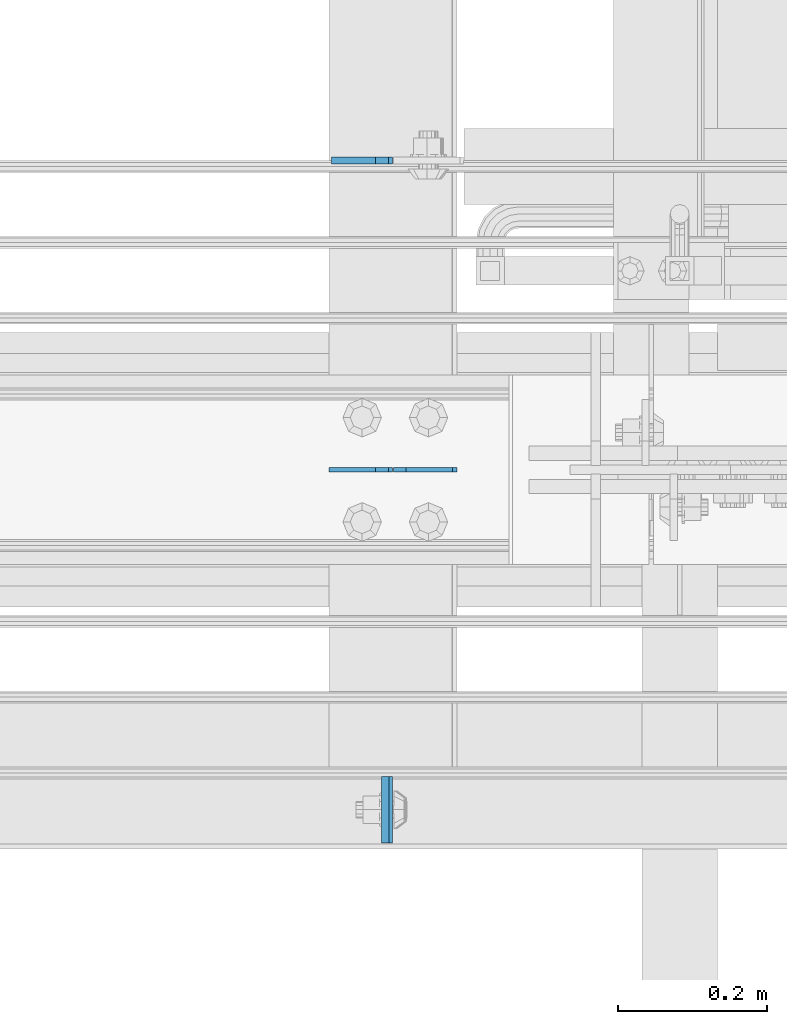
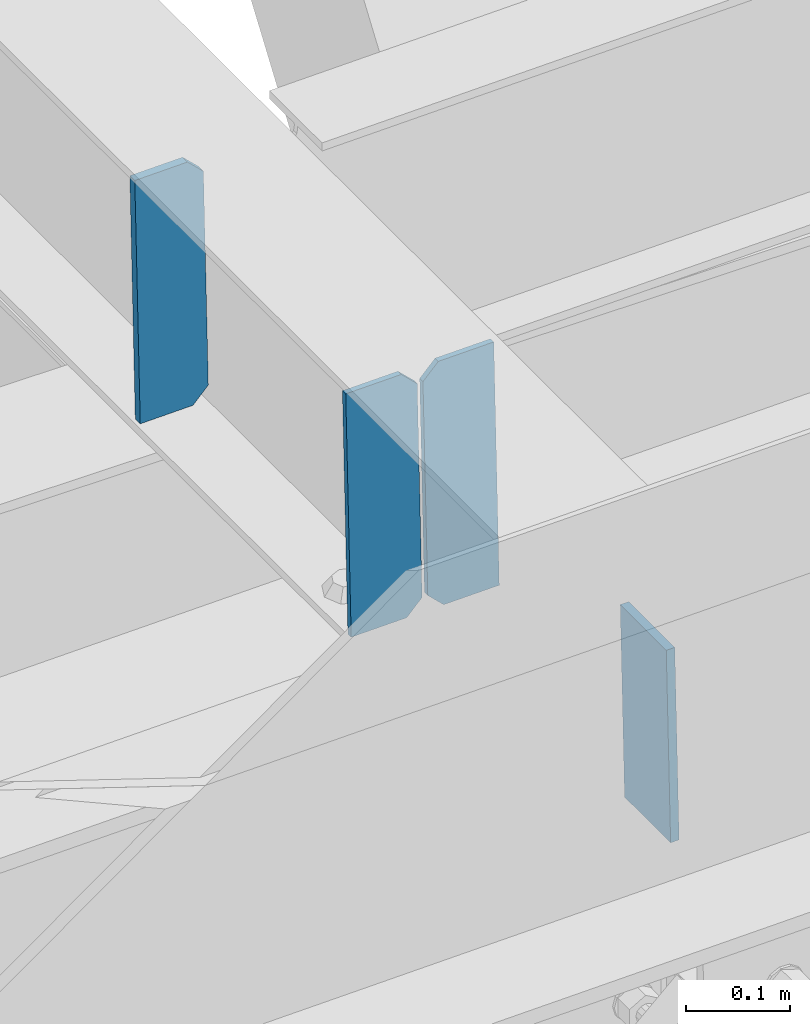
# One storey, part 3548 of 3843: 4 plates, 2 elements without a shape of their own.
"""IFC2X3 building model written with IfcOpenShell, lengths in millimetres."""

from ifc_helpers import new_model, si_unit, frame, origin_with_axes, place, context, subcontext, project, spatial, faceted_brep, material, type_object, element, aggregate, save


model = new_model("IFC2X3")

# Units and contexts
model_context = context("Model", 3, precision=1e-05, world=origin_with_axes())
body_context = subcontext(model_context, "Body", "Model", "MODEL_VIEW")
ifc_project = project(units=[si_unit("LENGTHUNIT", "METRE", prefix="MILLI"), si_unit("AREAUNIT", "SQUARE_METRE"), si_unit("VOLUMEUNIT", "CUBIC_METRE"), si_unit("MASSUNIT", "GRAM", prefix="KILO"), si_unit("TIMEUNIT", "SECOND"), si_unit("PLANEANGLEUNIT", "RADIAN"), si_unit("SOLIDANGLEUNIT", "STERADIAN"), si_unit("THERMODYNAMICTEMPERATUREUNIT", "DEGREE_CELSIUS"), si_unit("LUMINOUSINTENSITYUNIT", "LUMEN")], contexts=[model_context])

# Site, building, storey
site_placement = place(None, origin_with_axes())
site = spatial("IfcSite", under=ifc_project, at=site_placement, CompositionType="ELEMENT")
building_placement = place(site_placement, origin_with_axes())
building = spatial("IfcBuilding", under=site, at=building_placement, Name="Undefined", CompositionType="ELEMENT")
storey_placement = place(building_placement, origin_with_axes())
storey = spatial("IfcBuildingStorey", under=building, at=storey_placement, Name="Undefined", CompositionType="ELEMENT", Elevation=0.0)

# Assembly, plate
assembly_1_placement = place(storey_placement, origin_with_axes())
assembly_1 = element("IfcElementAssembly", 1, at=assembly_1_placement, inside=storey, Name="BEAM", AssemblyPlace="NOTDEFINED", PredefinedType="RIGID_FRAME")
ifc_material = material(Name="STEEL/A572-50")
plate_type_1 = type_object("IfcPlateType", PredefinedType="NOTDEFINED")
plate_1_placement = place(assembly_1_placement, frame((80453.4886954471, 14498.6375, 46619.7947536116), z_axis=(0.0, 1.0, 0.0), x_axis=(0.0211520550054438, 0.0, -0.999776270257025)))
plate_1 = element("IfcPlate", 2, at=plate_1_placement, type_object=plate_type_1, material=ifc_material, Name="PLATE", context=body_context, shape_type="Brep", body=[
    faceted_brep([(0.0, -4.76249999999709, 0.0), (0.0, -4.76249999999709, 88.9000015258789), (0.0, 4.76249999999709, 88.9000015258789), (0.0, 4.76249999999709, 0.0), (228.600006102781, -4.7625000004191, 88.9000015257589), (228.600006102781, 4.76249999954598, 88.9000015257443), (228.600006103079, -4.7625000004482, 7.27595761418343e-12), (228.600006103079, 4.76249999954598, -7.27595761418343e-12)], [[[0, 1, 2, 3]], [[1, 4, 5, 2]], [[4, 6, 7, 5]], [[6, 0, 3, 7]], [[5, 7, 3, 2]], [[6, 4, 1, 0]]]),
])
aggregate(assembly_1, [plate_1])

# Assembly, plates
assembly_2_placement = place(storey_placement, origin_with_axes())
assembly_2 = element("IfcElementAssembly", 3, at=assembly_2_placement, inside=storey, Name="BEAM", AssemblyPlace="NOTDEFINED", PredefinedType="RIGID_FRAME")
plate_type_2 = type_object("IfcPlateType", PredefinedType="NOTDEFINED")
plate_2_placement = place(assembly_2_placement, frame((80549.4964783459, 14998.7000000062, 46359.8298575578), z_axis=(-0.0211520980073474, 0.0, 0.999776269347241), x_axis=(-0.999776270257024, 0.0, -0.0211520550054595)))
plate_2 = element("IfcPlate", 4, at=plate_2_placement, type_object=plate_type_2, material=ifc_material, Name="STIFFENER", context=body_context, shape_type="Brep", body=[
    faceted_brep([(0.0, -3.17499999999927, 0.0), (6.83940015733242e-10, -3.17499999996653, 288.924999998613), (6.54836185276508e-10, 3.17500000001746, 288.924999998591), (0.0, 3.17499999999927, 0.0), (61.9125003828667, -3.17499999997744, 288.924999998599), (61.9125003828522, 3.17500000002838, 288.924999998584), (79.3750000013097, -3.17499999997744, 271.462500380039), (79.375000001266, 3.17500000002838, 271.462500380017), (79.375000000713, -3.17499999999927, 17.4624996185448), (79.3750000006694, 3.17500000000291, 17.462499618523), (61.9125003821828, -3.17499999999563, -1.45519152283669e-11), (61.9125003821682, 3.17500000000655, -2.91038304567337e-11)], [[[0, 1, 2, 3]], [[1, 4, 5, 2]], [[4, 6, 7, 5]], [[6, 8, 9, 7]], [[8, 10, 11, 9]], [[10, 0, 3, 11]], [[5, 7, 9, 11, 3, 2]], [[10, 8, 6, 4, 1, 0]]]),
])
plate_3_placement = place(assembly_2_placement, frame((80463.7906576556, 14998.7000000062, 46358.0165939561), z_axis=(-0.0211520980073474, 0.0, 0.999776269347241), x_axis=(-0.999776270257024, 0.0, -0.0211520550054595)))
plate_3 = element("IfcPlate", 5, at=plate_3_placement, type_object=plate_type_2, material=ifc_material, Name="STIFFENER", context=body_context, shape_type="Brep", body=[
    faceted_brep([(5.82076609134674e-11, -3.17499999999927, 17.4624996185667), (6.25732354819775e-10, -3.17499999997744, 271.462500380054), (5.82076609134674e-10, 3.17500000002474, 271.462500380039), (0.0, 3.17500000000655, 17.4624996185521), (17.462499619156, -3.17499999997744, 288.924999998606), (17.4624996191269, 3.17500000002474, 288.924999998591), (79.3750000013242, -3.17500000025029, 288.924999998591), (79.3750000013097, 3.1749999997337, 288.92499999857), (79.3750000006548, -3.17500000026484, -2.18278728425503e-11), (79.3750000006403, 3.17499999969732, -2.91038304567337e-11), (17.4624996184866, -3.17500000000291, 7.27595761418343e-12), (17.462499618443, 3.17500000000291, -7.27595761418343e-12)], [[[0, 1, 2, 3]], [[1, 4, 5, 2]], [[4, 6, 7, 5]], [[6, 8, 9, 7]], [[8, 10, 11, 9]], [[10, 0, 3, 11]], [[5, 7, 9, 11, 3, 2]], [[10, 8, 6, 4, 1, 0]]]),
])
plate_type_3 = type_object("IfcPlateType", PredefinedType="NOTDEFINED")
plate_4_placement = place(assembly_2_placement, frame((80463.7906576556, 15413.0375, 46358.0165939561), z_axis=(-0.0211520980073474, 0.0, 0.999776269347241), x_axis=(-0.999776270257024, 0.0, -0.0211520550054595)))
plate_4 = element("IfcPlate", 6, at=plate_4_placement, type_object=plate_type_3, material=ifc_material, Name="PLATE", context=body_context, shape_type="Brep", body=[
    faceted_brep([(-1.45519152283669e-11, -4.76250000000073, 17.4624996184939), (-3.34694050252438e-10, -4.76250000000073, 271.462500379137), (-3.34694050252438e-10, 4.76250000000073, 271.462500379137), (-1.45519152283669e-11, 4.76250000000073, 17.4624996184939), (17.4624996182974, -4.76250000000073, 288.924999997646), (17.4624996182974, 4.76250000000073, 288.924999997646), (76.2000000009575, -4.76250000000073, 288.924999997696), (76.2000000009575, 4.76250000000073, 288.924999997696), (76.2000000012922, -4.76250000000073, 7.27595761418343e-11), (76.2000000012922, 4.76250000000073, 7.27595761418343e-11), (17.4624996186321, -4.76250000000073, 7.27595761418343e-12), (17.4624996186321, 4.76250000000073, 7.27595761418343e-12)], [[[0, 1, 2, 3]], [[1, 4, 5, 2]], [[4, 6, 7, 5]], [[6, 8, 9, 7]], [[8, 10, 11, 9]], [[10, 0, 3, 11]], [[5, 7, 9, 11, 3, 2]], [[10, 8, 6, 4, 1, 0]]]),
])
aggregate(assembly_2, [plate_4, plate_2, plate_3])

save(model, "model.ifc")
